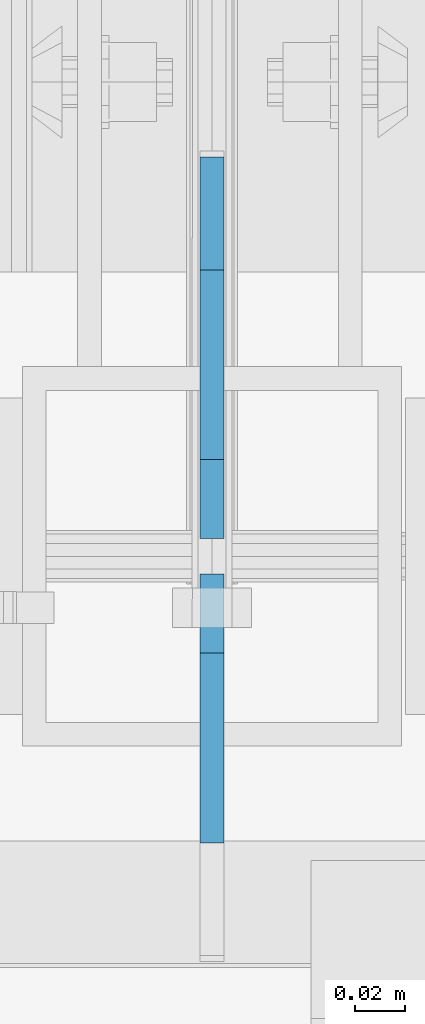
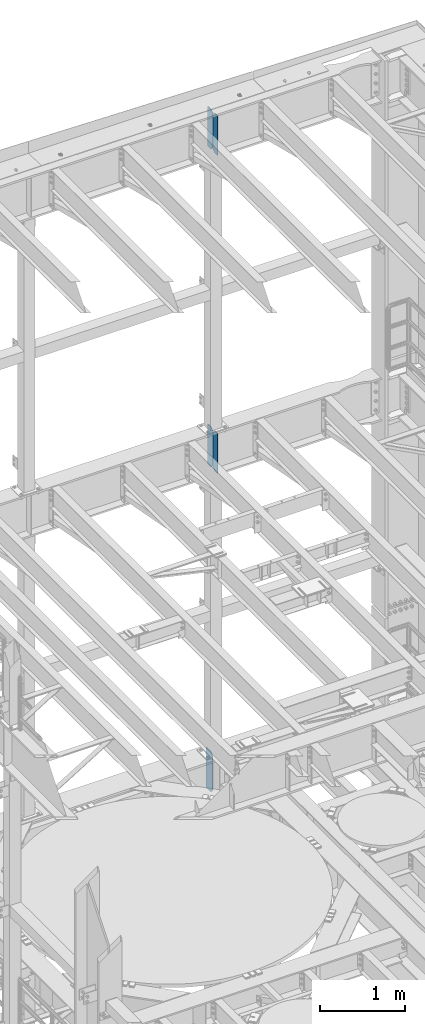
# One storey, part 1800 of 1876: 5 plates, 3 elements without a shape of their own.
"""IFC2X3 building model written with IfcOpenShell, lengths in millimetres."""

from ifc_helpers import new_model, si_unit, frame, origin_with_axes, place, context, subcontext, project, spatial, faceted_brep, material, type_object, element, aggregate, save


model = new_model("IFC2X3")

# Units and contexts
model_context = context("Model", 3, precision=1e-05, world=origin_with_axes())
body_context = subcontext(model_context, "Body", "Model", "MODEL_VIEW")
ifc_project = project(units=[si_unit("LENGTHUNIT", "METRE", prefix="MILLI"), si_unit("AREAUNIT", "SQUARE_METRE"), si_unit("VOLUMEUNIT", "CUBIC_METRE"), si_unit("MASSUNIT", "GRAM", prefix="KILO"), si_unit("TIMEUNIT", "SECOND"), si_unit("PLANEANGLEUNIT", "RADIAN"), si_unit("SOLIDANGLEUNIT", "STERADIAN"), si_unit("THERMODYNAMICTEMPERATUREUNIT", "DEGREE_CELSIUS"), si_unit("LUMINOUSINTENSITYUNIT", "LUMEN")], contexts=[model_context])

# Site, building, storey
site_placement = place(None, origin_with_axes())
site = spatial("IfcSite", under=ifc_project, at=site_placement, CompositionType="ELEMENT")
building_placement = place(site_placement, origin_with_axes())
building = spatial("IfcBuilding", under=site, at=building_placement, Name="Undefined", CompositionType="ELEMENT")
storey_placement = place(building_placement, origin_with_axes())
storey = spatial("IfcBuildingStorey", under=building, at=storey_placement, Name="Undefined", CompositionType="ELEMENT", Elevation=0.0)

# Assembly, plate
assembly_1_placement = place(storey_placement, origin_with_axes())
assembly_1 = element("IfcElementAssembly", 1, at=assembly_1_placement, inside=storey, Name="BEAM", AssemblyPlace="NOTDEFINED", PredefinedType="RIGID_FRAME")
ifc_material = material(Name="STEEL/A36")
plate_type_1 = type_object("IfcPlateType", PredefinedType="NOTDEFINED")
plate_1_placement = place(assembly_1_placement, frame((5080.0, 13723.9375, 12707.9375), z_axis=(0.0, 0.0, 1.0), x_axis=(0.0, 1.0, 0.0)))
plate_1 = element("IfcPlate", 2, at=plate_1_placement, type_object=plate_type_1, material=ifc_material, Name="PLATE", context=body_context, shape_type="Brep", body=[
    faceted_brep([(0.0, -4.76249999999982, 38.0999984741211), (0.0, -4.76249999999982, 536.574989318848), (0.0, 4.76249999999982, 536.574989318848), (0.0, 4.76249999999982, 38.0999984741211), (38.0999984741211, -4.76249999999982, 574.674987792969), (38.0999984741211, 4.76249999999982, 574.674987792969), (152.39999389651, -4.76250000000255, 574.674987792969), (152.39999389651, 4.76249999999891, 574.674987792969), (152.399993896484, -4.76249999999982, 0.0), (152.399993896484, 4.76249999999982, 0.0), (38.0999984741211, -4.76249999999982, 0.0), (38.0999984741211, 4.76249999999982, 0.0)], [[[0, 1, 2, 3]], [[1, 4, 5, 2]], [[4, 6, 7, 5]], [[6, 8, 9, 7]], [[8, 10, 11, 9]], [[10, 0, 3, 11]], [[5, 7, 9, 11, 3, 2]], [[10, 8, 6, 4, 1, 0]]]),
])
aggregate(assembly_1, [plate_1])

# Assembly, plates
assembly_2_placement = place(storey_placement, origin_with_axes())
assembly_2 = element("IfcElementAssembly", 3, at=assembly_2_placement, inside=storey, Name="BEAM", AssemblyPlace="NOTDEFINED", PredefinedType="RIGID_FRAME")
plate_type_2 = type_object("IfcPlateType", PredefinedType="NOTDEFINED")
plate_2_placement = place(assembly_2_placement, frame((5080.0, 13600.90625, 21958.3), z_axis=(0.0, 0.0, 1.0), x_axis=(0.0, 1.0, 0.0)))
plate_2 = element("IfcPlate", 4, at=plate_2_placement, type_object=plate_type_2, material=ifc_material, Name="PLATE", context=body_context, shape_type="Brep", body=[
    faceted_brep([(0.0, -4.76249999999982, 0.0), (0.0, -4.76249999999982, 571.5), (0.0, 4.76249999999982, 571.5), (0.0, 4.76249999999982, 0.0), (76.1999969482422, -4.76249999999982, 571.5), (76.1999969482422, 4.76249999999982, 571.5), (107.949996948242, -4.76249999999982, 539.75), (107.949996948242, 4.76249999999982, 539.75), (107.949996948242, -4.76249999999982, 31.75), (107.949996948242, 4.76249999999982, 31.75), (76.1999969482422, -4.76250000000073, 0.0), (76.1999969482422, 4.76250000000073, 0.0)], [[[0, 1, 2, 3]], [[1, 4, 5, 2]], [[4, 6, 7, 5]], [[6, 8, 9, 7]], [[8, 10, 11, 9]], [[10, 0, 3, 11]], [[5, 7, 9, 11, 3, 2]], [[10, 8, 6, 4, 1, 0]]]),
])
plate_3_placement = place(assembly_2_placement, frame((5080.0, 13723.14375, 21958.3), z_axis=(0.0, 0.0, 1.0), x_axis=(0.0, 1.0, 0.0)))
plate_3 = element("IfcPlate", 5, at=plate_3_placement, type_object=plate_type_2, material=ifc_material, Name="PLATE", context=body_context, shape_type="Brep", body=[
    faceted_brep([(-9.76996261670138e-14, -4.76250000000073, 31.75), (0.0, -4.76249999999982, 539.75), (0.0, 4.76249999999982, 539.75), (-9.76996261670138e-14, 4.76250000000073, 31.75), (31.75, -4.76249999999982, 571.5), (31.75, 4.76249999999982, 571.5), (107.949996948242, -4.76249999999982, 571.5), (107.949996948242, 4.76249999999982, 571.5), (107.950006484985, -4.76250000000073, 0.0), (107.950006484985, 4.76250000000073, 0.0), (31.75, -4.76250000000073, 0.0), (31.75, 4.76250000000073, 0.0)], [[[0, 1, 2, 3]], [[1, 4, 5, 2]], [[4, 6, 7, 5]], [[6, 8, 9, 7]], [[8, 10, 11, 9]], [[10, 0, 3, 11]], [[5, 7, 9, 11, 3, 2]], [[10, 8, 6, 4, 1, 0]]]),
])
aggregate(assembly_2, [plate_2, plate_3])

assembly_3_placement = place(storey_placement, origin_with_axes())
assembly_3 = element("IfcElementAssembly", 6, at=assembly_3_placement, inside=storey, Name="BEAM", AssemblyPlace="NOTDEFINED", PredefinedType="RIGID_FRAME")
plate_4_placement = place(assembly_3_placement, frame((5080.0, 13600.90625, 17386.3), z_axis=(0.0, 0.0, 1.0), x_axis=(0.0, 1.0, 0.0)))
plate_4 = element("IfcPlate", 7, at=plate_4_placement, type_object=plate_type_2, material=ifc_material, Name="PLATE", context=body_context, shape_type="Brep", body=[
    faceted_brep([(0.0, -4.76249999999982, 0.0), (0.0, -4.76249999999982, 571.5), (0.0, 4.76249999999982, 571.5), (0.0, 4.76249999999982, 0.0), (76.1999969482422, -4.76249999999982, 571.5), (76.1999969482422, 4.76249999999982, 571.5), (107.949996948242, -4.76249999999982, 539.75), (107.949996948242, 4.76249999999982, 539.75), (107.949996948242, -4.76249999999982, 31.75), (107.949996948242, 4.76249999999982, 31.75), (76.1999969482422, -4.76250000000073, 0.0), (76.1999969482422, 4.76250000000073, 0.0)], [[[0, 1, 2, 3]], [[1, 4, 5, 2]], [[4, 6, 7, 5]], [[6, 8, 9, 7]], [[8, 10, 11, 9]], [[10, 0, 3, 11]], [[5, 7, 9, 11, 3, 2]], [[10, 8, 6, 4, 1, 0]]]),
])
plate_5_placement = place(assembly_3_placement, frame((5080.0, 13723.14375, 17386.3), z_axis=(0.0, 0.0, 1.0), x_axis=(0.0, 1.0, 0.0)))
plate_5 = element("IfcPlate", 8, at=plate_5_placement, type_object=plate_type_2, material=ifc_material, Name="PLATE", context=body_context, shape_type="Brep", body=[
    faceted_brep([(-9.76996261670138e-14, -4.76250000000073, 31.75), (0.0, -4.76249999999982, 539.75), (0.0, 4.76249999999982, 539.75), (-9.76996261670138e-14, 4.76250000000073, 31.75), (31.75, -4.76249999999982, 571.5), (31.75, 4.76249999999982, 571.5), (107.949996948242, -4.76249999999982, 571.5), (107.949996948242, 4.76249999999982, 571.5), (107.950006484985, -4.76250000000073, 0.0), (107.950006484985, 4.76250000000073, 0.0), (31.75, -4.76250000000073, 0.0), (31.75, 4.76250000000073, 0.0)], [[[0, 1, 2, 3]], [[1, 4, 5, 2]], [[4, 6, 7, 5]], [[6, 8, 9, 7]], [[8, 10, 11, 9]], [[10, 0, 3, 11]], [[5, 7, 9, 11, 3, 2]], [[10, 8, 6, 4, 1, 0]]]),
])
aggregate(assembly_3, [plate_4, plate_5])

save(model, "model.ifc")
